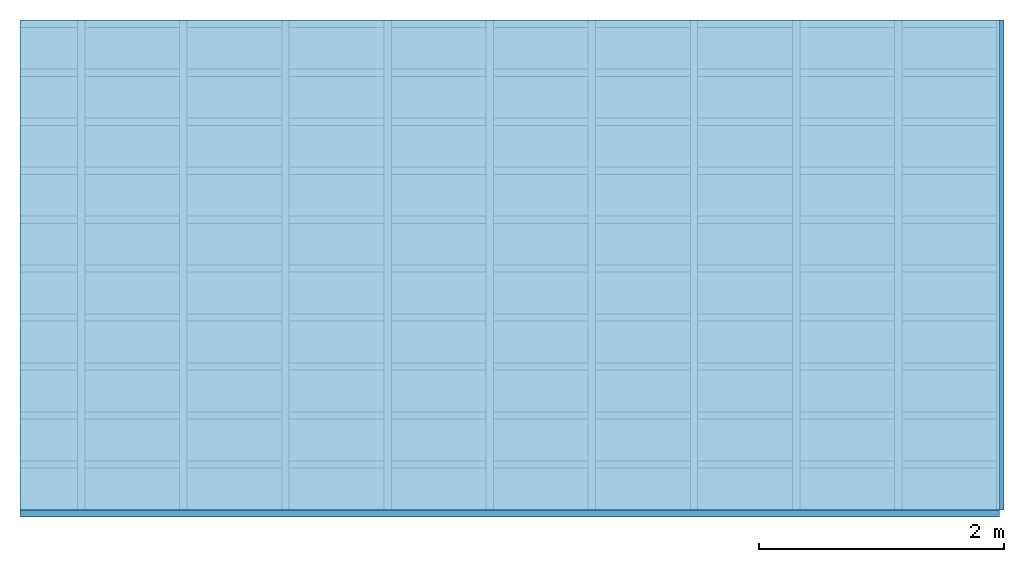
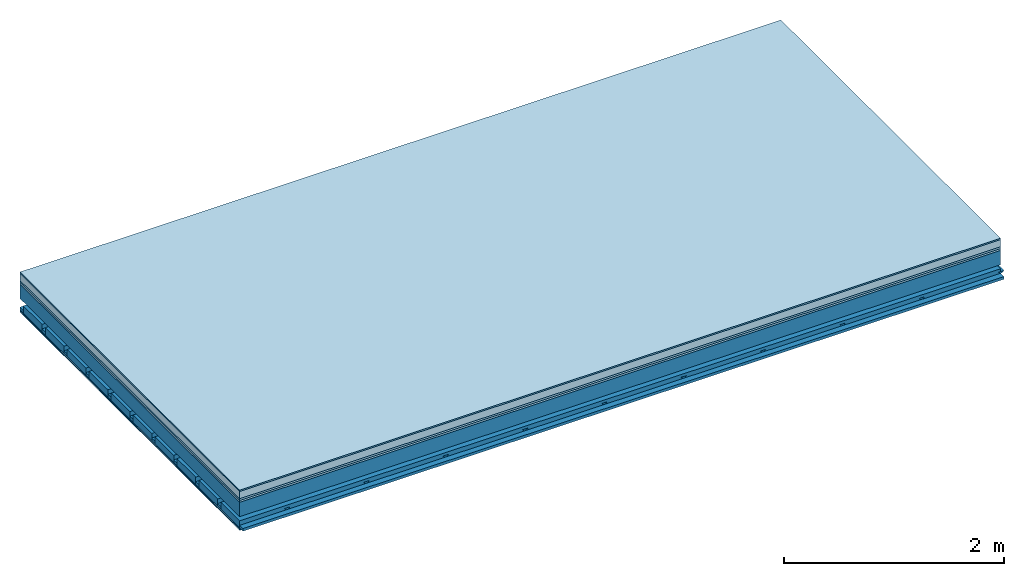
# One storey: 7 plates, 4 members, 1 element without a shape of its own.
"""IFC4 building model written with IfcOpenShell, lengths in metres."""

from ifc_helpers import new_model, si_unit, derived_unit, direction, frame, frame_2d, origin, origin_with_axes, place, context, project, spatial, polyline, rectangle, outline, extrude, material, layer, layer_set, type_object, element, aggregate, save


model = new_model("IFC4")

# Units and contexts
plan_context = context("Plan", 3, precision=1e-05, world=origin(), true_north=direction((0.0, 1.0)))
model_context = context("Model", 3, precision=1e-05, world=origin(), true_north=direction((0.0, 1.0)))
ifc_project = project(units=[si_unit("LENGTHUNIT", "METRE"), derived_unit("SOUNDPRESSUREUNIT", [(si_unit("PRESSUREUNIT", "PASCAL", prefix="MICRO"), 0)]), si_unit("ENERGYUNIT", "JOULE", prefix="MEGA"), si_unit("MASSUNIT", "GRAM", prefix="KILO"), derived_unit("THERMALTRANSMITTANCEUNIT", [(si_unit("POWERUNIT", "WATT"), 1), (si_unit("AREAUNIT", "SQUARE_METRE"), -1), (si_unit("THERMODYNAMICTEMPERATUREUNIT", "KELVIN"), -1)]), derived_unit("AREADENSITYUNIT", [(si_unit("MASSUNIT", "GRAM", prefix="KILO"), 1), (si_unit("AREAUNIT", "SQUARE_METRE"), -1)]), derived_unit("USERDEFINED", [(si_unit("ENERGYUNIT", "JOULE", prefix="MEGA"), 1), (si_unit("AREAUNIT", "SQUARE_METRE"), -1)])], contexts=[plan_context, model_context])

# Site, building, storey
site = spatial("IfcSite", under=ifc_project)
building_placement = place(None, origin())
building = spatial("IfcBuilding", under=site, at=building_placement)
storey_placement = place(building_placement, origin())
storey = spatial("IfcBuildingStorey", under=building, at=storey_placement)

# Slab, members, plates
ifc_material_1 = material(Category="11.013")
ifc_layer_1 = layer(ifc_material_1, 0.015, Name="Flooring")
ifc_material_2 = material(Name="Cement screed", Category="04.006")
ifc_layer_2 = layer(ifc_material_2, 0.08, Name="On-material")
ifc_material_3 = material(Name="Wood fiber generic product", Category="10.009")
ifc_layer_3 = layer(ifc_material_3, 0.02, Name="Impact sound insulation")
ifc_material_4 = material(Category="10.004")
ifc_layer_4 = layer(ifc_material_4, 0.02, Name="Additional insulation")
ifc_material_5 = material(Name="no composite action")
ifc_layer_5 = layer(ifc_material_5, 0.0, Name="Bond")
ifc_layer_6 = layer(None, 0.16, Name="Supporting structure")
ifc_layer_7 = layer(ifc_material_5, 0.0, Name="Bond")
ifc_layer_8 = layer(None, 0.095, Name="Coupling")
ifc_layer_9 = layer(None, 0.03, Name="Battens / profiles")
ifc_material_6 = material(Name="Plasterboard type A", Category="03.008")
ifc_layer_10 = layer(ifc_material_6, 0.0125, Name="Ceiling covering 1st layer")
ifc_layer_11 = layer(ifc_material_6, 0.0125, Name="Ceiling covering layer 2")
ifc_material_7 = material(Category="04.001")
ifc_layer_12 = layer(ifc_material_7, 0.003, Name="Surface / treatment")
ifc_layer_set = layer_set([ifc_layer_1, ifc_layer_2, ifc_layer_3, ifc_layer_4, ifc_layer_5, ifc_layer_6, ifc_layer_7, ifc_layer_8, ifc_layer_9, ifc_layer_10, ifc_layer_11, ifc_layer_12])
slab_type = type_object("IfcSlabType", Name="A2152", PredefinedType="NOTDEFINED", material=ifc_layer_set)
slab_placement = place(None, frame((0.0, 0.0, 0.0), z_axis=(0.0, 0.0, -1.0), x_axis=(1.0, 0.0, 0.0)))
slab = element("IfcSlab", 1, at=slab_placement, inside=storey, type_object=slab_type, material=ifc_layer_set, Name="Slab #1")
ifc_material_8 = material(Name="Solid timber panel")
member_1_placement = place(slab_placement, origin())
member_1 = element("IfcMember", 2, at=member_1_placement, material=ifc_material_8, Name="Supporting structure", context=plan_context, shape_type="SweptSolid", body=[
    extrude(rectangle(XDim=1.0, YDim=0.16, at=frame_2d((0.5, 0.08), x_axis=(1.0, 0.0))), frame((0.0, 4.0, 0.135), z_axis=(0.0, -1.0, 0.0), x_axis=(1.0, 0.0, 0.0)), (0.0, 0.0, 1.0), 4.0),
    extrude(rectangle(XDim=1.0, YDim=0.16, at=frame_2d((0.5, 0.08), x_axis=(1.0, 0.0))), frame((1.0, 4.0, 0.135), z_axis=(0.0, -1.0, 0.0), x_axis=(1.0, 0.0, 0.0)), (0.0, 0.0, 1.0), 4.0),
    extrude(rectangle(XDim=1.0, YDim=0.16, at=frame_2d((0.5, 0.08), x_axis=(1.0, 0.0))), frame((2.0, 4.0, 0.135), z_axis=(0.0, -1.0, 0.0), x_axis=(1.0, 0.0, 0.0)), (0.0, 0.0, 1.0), 4.0),
    extrude(rectangle(XDim=1.0, YDim=0.16, at=frame_2d((0.5, 0.08), x_axis=(1.0, 0.0))), frame((3.0, 4.0, 0.135), z_axis=(0.0, -1.0, 0.0), x_axis=(1.0, 0.0, 0.0)), (0.0, 0.0, 1.0), 4.0),
    extrude(rectangle(XDim=1.0, YDim=0.16, at=frame_2d((0.5, 0.08), x_axis=(1.0, 0.0))), frame((4.0, 4.0, 0.135), z_axis=(0.0, -1.0, 0.0), x_axis=(1.0, 0.0, 0.0)), (0.0, 0.0, 1.0), 4.0),
    extrude(rectangle(XDim=1.0, YDim=0.16, at=frame_2d((0.5, 0.08), x_axis=(1.0, 0.0))), frame((5.0, 4.0, 0.135), z_axis=(0.0, -1.0, 0.0), x_axis=(1.0, 0.0, 0.0)), (0.0, 0.0, 1.0), 4.0),
    extrude(rectangle(XDim=1.0, YDim=0.16, at=frame_2d((0.5, 0.08), x_axis=(1.0, 0.0))), frame((6.0, 4.0, 0.135), z_axis=(0.0, -1.0, 0.0), x_axis=(1.0, 0.0, 0.0)), (0.0, 0.0, 1.0), 4.0),
    extrude(rectangle(XDim=1.0, YDim=0.16, at=frame_2d((0.5, 0.08), x_axis=(1.0, 0.0))), frame((7.0, 4.0, 0.135), z_axis=(0.0, -1.0, 0.0), x_axis=(1.0, 0.0, 0.0)), (0.0, 0.0, 1.0), 4.0),
])
ifc_material_9 = material()
member_2_placement = place(slab_placement, origin())
member_2 = element("IfcMember", 3, at=member_2_placement, material=ifc_material_9, Name="Coupling", context=plan_context, shape_type="SweptSolid", body=[
    extrude(outline(polyline([(0.0, 0.0), (0.06, 0.0), (0.04, 0.02), (0.02, 0.02), (0.0, 0.0)])), frame((0.47, 4.0, 0.37), z_axis=(0.0, -1.0, 0.0), x_axis=(1.0, 0.0, 0.0)), (0.0, 0.0, 1.0), 4.0),
    extrude(outline(polyline([(0.0, 0.0), (0.06, 0.0), (0.04, 0.02), (0.02, 0.02), (0.0, 0.0)])), frame((1.304, 4.0, 0.37), z_axis=(0.0, -1.0, 0.0), x_axis=(1.0, 0.0, 0.0)), (0.0, 0.0, 1.0), 4.0),
    extrude(outline(polyline([(0.0, 0.0), (0.06, 0.0), (0.04, 0.02), (0.02, 0.02), (0.0, 0.0)])), frame((2.138, 4.0, 0.37), z_axis=(0.0, -1.0, 0.0), x_axis=(1.0, 0.0, 0.0)), (0.0, 0.0, 1.0), 4.0),
    extrude(outline(polyline([(0.0, 0.0), (0.06, 0.0), (0.04, 0.02), (0.02, 0.02), (0.0, 0.0)])), frame((2.972, 4.0, 0.37), z_axis=(0.0, -1.0, 0.0), x_axis=(1.0, 0.0, 0.0)), (0.0, 0.0, 1.0), 4.0),
    extrude(outline(polyline([(0.0, 0.0), (0.06, 0.0), (0.04, 0.02), (0.02, 0.02), (0.0, 0.0)])), frame((3.806, 4.0, 0.37), z_axis=(0.0, -1.0, 0.0), x_axis=(1.0, 0.0, 0.0)), (0.0, 0.0, 1.0), 4.0),
    extrude(outline(polyline([(0.0, 0.0), (0.06, 0.0), (0.04, 0.02), (0.02, 0.02), (0.0, 0.0)])), frame((4.64, 4.0, 0.37), z_axis=(0.0, -1.0, 0.0), x_axis=(1.0, 0.0, 0.0)), (0.0, 0.0, 1.0), 4.0),
    extrude(outline(polyline([(0.0, 0.0), (0.06, 0.0), (0.04, 0.02), (0.02, 0.02), (0.0, 0.0)])), frame((5.474, 4.0, 0.37), z_axis=(0.0, -1.0, 0.0), x_axis=(1.0, 0.0, 0.0)), (0.0, 0.0, 1.0), 4.0),
    extrude(outline(polyline([(0.0, 0.0), (0.06, 0.0), (0.04, 0.02), (0.02, 0.02), (0.0, 0.0)])), frame((6.308, 4.0, 0.37), z_axis=(0.0, -1.0, 0.0), x_axis=(1.0, 0.0, 0.0)), (0.0, 0.0, 1.0), 4.0),
    extrude(outline(polyline([(0.0, 0.0), (0.06, 0.0), (0.04, 0.02), (0.02, 0.02), (0.0, 0.0)])), frame((7.142, 4.0, 0.37), z_axis=(0.0, -1.0, 0.0), x_axis=(1.0, 0.0, 0.0)), (0.0, 0.0, 1.0), 4.0),
    extrude(outline(polyline([(0.0, 0.0), (0.06, 0.0), (0.04, 0.02), (0.02, 0.02), (0.0, 0.0)])), frame((7.976, 4.0, 0.37), z_axis=(0.0, -1.0, 0.0), x_axis=(1.0, 0.0, 0.0)), (0.0, 0.0, 1.0), 4.0),
])
member_3_placement = place(slab_placement, origin())
member_3 = element("IfcMember", 4, at=member_3_placement, material=ifc_material_9, Name="Battens / profiles", context=plan_context, shape_type="SweptSolid", body=[
    extrude(rectangle(XDim=0.06, YDim=0.03, at=frame_2d((0.03, 0.015), x_axis=(1.0, 0.0))), frame((0.0, 0.0, 0.39), z_axis=(1.0, 0.0, 0.0), x_axis=(0.0, 1.0, 0.0)), (0.0, 0.0, 1.0), 8.0),
    extrude(rectangle(XDim=0.06, YDim=0.03, at=frame_2d((0.03, 0.015), x_axis=(1.0, 0.0))), frame((0.0, 0.4, 0.39), z_axis=(1.0, 0.0, 0.0), x_axis=(0.0, 1.0, 0.0)), (0.0, 0.0, 1.0), 8.0),
    extrude(rectangle(XDim=0.06, YDim=0.03, at=frame_2d((0.03, 0.015), x_axis=(1.0, 0.0))), frame((0.0, 0.8, 0.39), z_axis=(1.0, 0.0, 0.0), x_axis=(0.0, 1.0, 0.0)), (0.0, 0.0, 1.0), 8.0),
    extrude(rectangle(XDim=0.06, YDim=0.03, at=frame_2d((0.03, 0.015), x_axis=(1.0, 0.0))), frame((0.0, 1.2, 0.39), z_axis=(1.0, 0.0, 0.0), x_axis=(0.0, 1.0, 0.0)), (0.0, 0.0, 1.0), 8.0),
    extrude(rectangle(XDim=0.06, YDim=0.03, at=frame_2d((0.03, 0.015), x_axis=(1.0, 0.0))), frame((0.0, 1.6, 0.39), z_axis=(1.0, 0.0, 0.0), x_axis=(0.0, 1.0, 0.0)), (0.0, 0.0, 1.0), 8.0),
    extrude(rectangle(XDim=0.06, YDim=0.03, at=frame_2d((0.03, 0.015), x_axis=(1.0, 0.0))), frame((0.0, 2.0, 0.39), z_axis=(1.0, 0.0, 0.0), x_axis=(0.0, 1.0, 0.0)), (0.0, 0.0, 1.0), 8.0),
    extrude(rectangle(XDim=0.06, YDim=0.03, at=frame_2d((0.03, 0.015), x_axis=(1.0, 0.0))), frame((0.0, 2.4, 0.39), z_axis=(1.0, 0.0, 0.0), x_axis=(0.0, 1.0, 0.0)), (0.0, 0.0, 1.0), 8.0),
    extrude(rectangle(XDim=0.06, YDim=0.03, at=frame_2d((0.03, 0.015), x_axis=(1.0, 0.0))), frame((0.0, 2.8, 0.39), z_axis=(1.0, 0.0, 0.0), x_axis=(0.0, 1.0, 0.0)), (0.0, 0.0, 1.0), 8.0),
    extrude(rectangle(XDim=0.06, YDim=0.03, at=frame_2d((0.03, 0.015), x_axis=(1.0, 0.0))), frame((0.0, 3.2, 0.39), z_axis=(1.0, 0.0, 0.0), x_axis=(0.0, 1.0, 0.0)), (0.0, 0.0, 1.0), 8.0),
    extrude(rectangle(XDim=0.06, YDim=0.03, at=frame_2d((0.03, 0.015), x_axis=(1.0, 0.0))), frame((0.0, 3.6, 0.39), z_axis=(1.0, 0.0, 0.0), x_axis=(0.0, 1.0, 0.0)), (0.0, 0.0, 1.0), 8.0),
    extrude(rectangle(XDim=0.06, YDim=0.03, at=frame_2d((0.03, 0.015), x_axis=(1.0, 0.0))), frame((0.0, 4.0, 0.39), z_axis=(1.0, 0.0, 0.0), x_axis=(0.0, 1.0, 0.0)), (0.0, 0.0, 1.0), 8.0),
])
ifc_material_10 = material()
member_4_placement = place(slab_placement, origin())
member_4 = element("IfcMember", 5, at=member_4_placement, material=ifc_material_10, Name="Cavity", context=plan_context, shape_type="SweptSolid", body=[
    extrude(rectangle(XDim=0.34, YDim=0.08, at=frame_2d((0.17, 0.04), x_axis=(1.0, 0.0))), frame((0.0, 0.06, 0.34), z_axis=(1.0, 0.0, 0.0), x_axis=(0.0, 1.0, 0.0)), (0.0, 0.0, 1.0), 8.0),
    extrude(rectangle(XDim=0.34, YDim=0.08, at=frame_2d((0.17, 0.04), x_axis=(1.0, 0.0))), frame((0.0, 0.46, 0.34), z_axis=(1.0, 0.0, 0.0), x_axis=(0.0, 1.0, 0.0)), (0.0, 0.0, 1.0), 8.0),
    extrude(rectangle(XDim=0.34, YDim=0.08, at=frame_2d((0.17, 0.04), x_axis=(1.0, 0.0))), frame((0.0, 0.86, 0.34), z_axis=(1.0, 0.0, 0.0), x_axis=(0.0, 1.0, 0.0)), (0.0, 0.0, 1.0), 8.0),
    extrude(rectangle(XDim=0.34, YDim=0.08, at=frame_2d((0.17, 0.04), x_axis=(1.0, 0.0))), frame((0.0, 1.26, 0.34), z_axis=(1.0, 0.0, 0.0), x_axis=(0.0, 1.0, 0.0)), (0.0, 0.0, 1.0), 8.0),
    extrude(rectangle(XDim=0.34, YDim=0.08, at=frame_2d((0.17, 0.04), x_axis=(1.0, 0.0))), frame((0.0, 1.66, 0.34), z_axis=(1.0, 0.0, 0.0), x_axis=(0.0, 1.0, 0.0)), (0.0, 0.0, 1.0), 8.0),
    extrude(rectangle(XDim=0.34, YDim=0.08, at=frame_2d((0.17, 0.04), x_axis=(1.0, 0.0))), frame((0.0, 2.06, 0.34), z_axis=(1.0, 0.0, 0.0), x_axis=(0.0, 1.0, 0.0)), (0.0, 0.0, 1.0), 8.0),
    extrude(rectangle(XDim=0.34, YDim=0.08, at=frame_2d((0.17, 0.04), x_axis=(1.0, 0.0))), frame((0.0, 2.46, 0.34), z_axis=(1.0, 0.0, 0.0), x_axis=(0.0, 1.0, 0.0)), (0.0, 0.0, 1.0), 8.0),
    extrude(rectangle(XDim=0.34, YDim=0.08, at=frame_2d((0.17, 0.04), x_axis=(1.0, 0.0))), frame((0.0, 2.86, 0.34), z_axis=(1.0, 0.0, 0.0), x_axis=(0.0, 1.0, 0.0)), (0.0, 0.0, 1.0), 8.0),
    extrude(rectangle(XDim=0.34, YDim=0.08, at=frame_2d((0.17, 0.04), x_axis=(1.0, 0.0))), frame((0.0, 3.26, 0.34), z_axis=(1.0, 0.0, 0.0), x_axis=(0.0, 1.0, 0.0)), (0.0, 0.0, 1.0), 8.0),
    extrude(rectangle(XDim=0.34, YDim=0.08, at=frame_2d((0.17, 0.04), x_axis=(1.0, 0.0))), frame((0.0, 3.66, 0.34), z_axis=(1.0, 0.0, 0.0), x_axis=(0.0, 1.0, 0.0)), (0.0, 0.0, 1.0), 8.0),
])
plate_1_placement = place(slab_placement, origin())
plate_1 = element("IfcPlate", 6, at=plate_1_placement, material=ifc_material_1, Name="Flooring", context=plan_context, shape_type="SweptSolid", body=[
    extrude(rectangle(XDim=8.0, YDim=4.0, at=frame_2d((4.0, 2.0), x_axis=(1.0, 0.0))), origin_with_axes(), (0.0, 0.0, 1.0), 0.015),
])
plate_2_placement = place(slab_placement, origin())
plate_2 = element("IfcPlate", 7, at=plate_2_placement, material=ifc_material_2, Name="On-material", context=plan_context, shape_type="SweptSolid", body=[
    extrude(rectangle(XDim=8.0, YDim=4.0, at=frame_2d((4.0, 2.0), x_axis=(1.0, 0.0))), frame((0.0, 0.0, 0.015), z_axis=(0.0, 0.0, 1.0), x_axis=(1.0, 0.0, 0.0)), (0.0, 0.0, 1.0), 0.08),
])
plate_3_placement = place(slab_placement, origin())
plate_3 = element("IfcPlate", 8, at=plate_3_placement, material=ifc_material_3, Name="Impact sound insulation", context=plan_context, shape_type="SweptSolid", body=[
    extrude(rectangle(XDim=8.0, YDim=4.0, at=frame_2d((4.0, 2.0), x_axis=(1.0, 0.0))), frame((0.0, 0.0, 0.095), z_axis=(0.0, 0.0, 1.0), x_axis=(1.0, 0.0, 0.0)), (0.0, 0.0, 1.0), 0.02),
])
plate_4_placement = place(slab_placement, origin())
plate_4 = element("IfcPlate", 9, at=plate_4_placement, material=ifc_material_4, Name="Additional insulation", context=plan_context, shape_type="SweptSolid", body=[
    extrude(rectangle(XDim=8.0, YDim=4.0, at=frame_2d((4.0, 2.0), x_axis=(1.0, 0.0))), frame((0.0, 0.0, 0.115), z_axis=(0.0, 0.0, 1.0), x_axis=(1.0, 0.0, 0.0)), (0.0, 0.0, 1.0), 0.02),
])
plate_5_placement = place(slab_placement, origin())
plate_5 = element("IfcPlate", 10, at=plate_5_placement, material=ifc_material_6, Name="Ceiling covering 1st layer", context=plan_context, shape_type="SweptSolid", body=[
    extrude(rectangle(XDim=8.0, YDim=4.0, at=frame_2d((4.0, 2.0), x_axis=(1.0, 0.0))), frame((0.0, 0.0, 0.42), z_axis=(0.0, 0.0, 1.0), x_axis=(1.0, 0.0, 0.0)), (0.0, 0.0, 1.0), 0.0125),
])
plate_6_placement = place(slab_placement, origin())
plate_6 = element("IfcPlate", 11, at=plate_6_placement, material=ifc_material_6, Name="Ceiling covering layer 2", context=plan_context, shape_type="SweptSolid", body=[
    extrude(rectangle(XDim=8.0, YDim=4.0, at=frame_2d((4.0, 2.0), x_axis=(1.0, 0.0))), frame((0.0, 0.0, 0.4325), z_axis=(0.0, 0.0, 1.0), x_axis=(1.0, 0.0, 0.0)), (0.0, 0.0, 1.0), 0.0125),
])
plate_7_placement = place(slab_placement, origin())
plate_7 = element("IfcPlate", 12, at=plate_7_placement, material=ifc_material_7, Name="Surface / treatment", context=plan_context, shape_type="SweptSolid", body=[
    extrude(rectangle(XDim=8.0, YDim=4.0, at=frame_2d((4.0, 2.0), x_axis=(1.0, 0.0))), frame((0.0, 0.0, 0.445), z_axis=(0.0, 0.0, 1.0), x_axis=(1.0, 0.0, 0.0)), (0.0, 0.0, 1.0), 0.003),
])
aggregate(slab, [plate_1, plate_2, plate_3, plate_4, member_1, member_2, member_3, member_4, plate_5, plate_6, plate_7])

save(model, "model.ifc")
